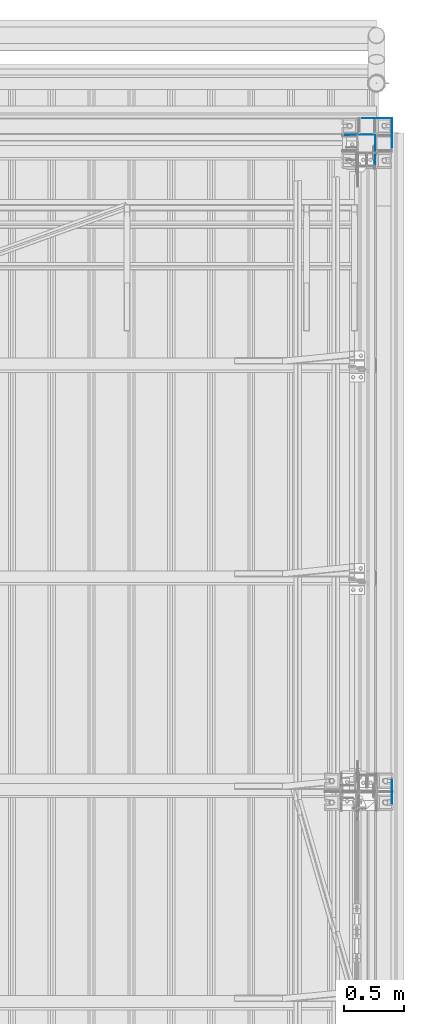
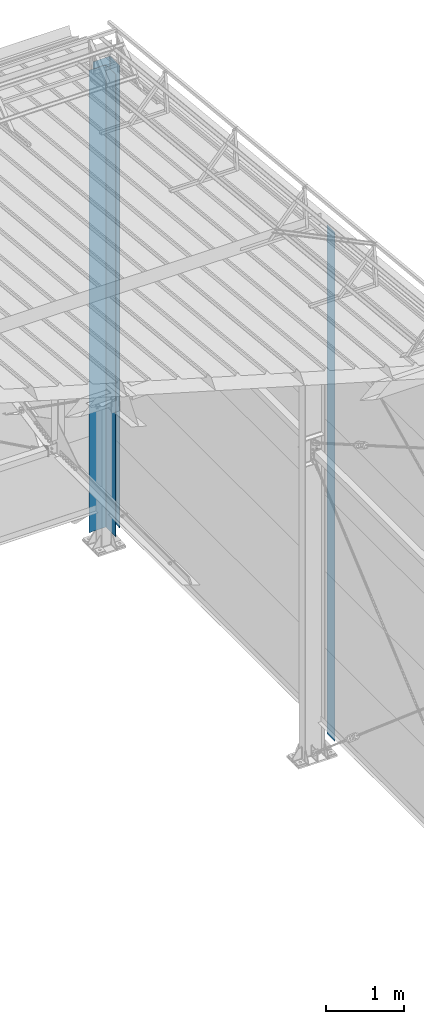
# One storey, part 17 of 709: 3 columns, 3 elements without a shape of their own.
"""IFC4 building model written with IfcOpenShell, lengths in millimetres."""

from ifc_helpers import new_model, si_unit, direction, frame, origin_with_axes, place, context, subcontext, project, spatial, line, indexed_curve, outline, extrude, material, element, aggregate, save


model = new_model("IFC4")

# Units and contexts
model_context = context("Model", 3, precision=0.2, world=origin_with_axes(), true_north=direction((0.0, 1.0)))
body_context = subcontext(model_context, "Body", "Model", "MODEL_VIEW")
ifc_project = project(units=[si_unit("LENGTHUNIT", "METRE", prefix="MILLI"), si_unit("AREAUNIT", "SQUARE_METRE"), si_unit("VOLUMEUNIT", "CUBIC_METRE"), si_unit("MASSUNIT", "GRAM", prefix="KILO"), si_unit("TIMEUNIT", "SECOND"), si_unit("PLANEANGLEUNIT", "RADIAN"), si_unit("SOLIDANGLEUNIT", "STERADIAN"), si_unit("THERMODYNAMICTEMPERATUREUNIT", "DEGREE_CELSIUS"), si_unit("LUMINOUSINTENSITYUNIT", "LUMEN")], contexts=[model_context])

# Site, building, storey
site_placement = place(None, origin_with_axes())
site = spatial("IfcSite", under=ifc_project, at=site_placement, CompositionType="ELEMENT")
building_placement = place(site_placement, origin_with_axes())
building = spatial("IfcBuilding", under=site, at=building_placement, Name="Undefined", CompositionType="ELEMENT")
storey_placement = place(building_placement, origin_with_axes())
storey = spatial("IfcBuildingStorey", under=building, at=storey_placement, Name="Undefined", CompositionType="ELEMENT", Elevation=0.0)

# Assembly, column
assembly_1_placement = place(storey_placement, frame((50130.0, 22130.0, 0.0), z_axis=(0.0, -1.0, 0.0), x_axis=(0.0, 0.0, 1.0)))
assembly_1 = element("IfcElementAssembly", 1, at=assembly_1_placement, inside=storey)
ifc_material = material(Name="Steel_Undefined", Category="STEEL")
column_1_placement = place(assembly_1_placement, origin_with_axes())
column_1 = element("IfcColumn", 2, at=column_1_placement, material=ifc_material, context=body_context, shape_type="SolidModel", body=[
    extrude(outline(indexed_curve([(0.0, 0.0), (250.0, 0.0), (250.0, 3.0), (220.0, 3.0), (220.0, 2.0), (249.0, 2.0), (249.0, 1.0), (1.0, 1.0), (1.0, 249.0), (2.0, 249.0), (2.0, 220.0), (3.0, 220.0), (3.0, 250.0), (0.0, 250.0)], segments=[line(1, 2, 3, 4, 5, 6, 7, 8, 9, 10, 11, 12, 13, 14, 1)])), frame((0.0, 0.0, 0.0), z_axis=(-1.0, 0.0, 0.0), x_axis=(0.0, 0.0, 1.0)), (0.0, 0.0, -1.0), 7196.92297),
])
aggregate(assembly_1, [column_1])

assembly_2_placement = place(storey_placement, frame((49990.0, 21990.0, 0.0), z_axis=(0.0, -1.0, 0.0), x_axis=(0.0, 0.0, 1.0)))
assembly_2 = element("IfcElementAssembly", 3, at=assembly_2_placement, inside=storey)
column_2_placement = place(assembly_2_placement, origin_with_axes())
column_2 = element("IfcColumn", 4, at=column_2_placement, material=ifc_material, context=body_context, shape_type="SolidModel", body=[
    extrude(outline(indexed_curve([(0.0, 0.0), (250.0, 0.0), (250.0, 3.0), (220.0, 3.0), (220.0, 2.0), (249.0, 2.0), (249.0, 1.0), (1.0, 1.0), (1.0, 249.0), (2.0, 249.0), (2.0, 220.0), (3.0, 220.0), (3.0, 250.0), (0.0, 250.0)], segments=[line(1, 2, 3, 4, 5, 6, 7, 8, 9, 10, 11, 12, 13, 14, 1)])), frame((0.0, 0.0, 0.0), z_axis=(-1.0, 0.0, 0.0), x_axis=(0.0, 0.0, 1.0)), (0.0, 0.0, -1.0), 7196.92297),
])
aggregate(assembly_2, [column_2])

assembly_3_placement = place(storey_placement, frame((50130.0, 16500.0, 0.0), z_axis=(1.0, 0.0, 0.0), x_axis=(0.0, 0.0, 1.0)))
assembly_3 = element("IfcElementAssembly", 5, at=assembly_3_placement, inside=storey)
column_3_placement = place(assembly_3_placement, origin_with_axes())
column_3 = element("IfcColumn", 6, at=column_3_placement, material=ifc_material, context=body_context, shape_type="SolidModel", body=[
    extrude(outline(indexed_curve([(-0.375, -100.0), (1.245, -100.0), (1.245, -50.0), (0.495, -50.0), (0.495, -99.25), (0.375, -99.25), (0.375, 99.25), (0.495, 99.25), (0.495, 50.0), (1.245, 50.0), (1.245, 100.0), (-0.375, 100.0)], segments=[line(1, 2, 3, 4, 5, 6, 7, 8, 9, 10, 11, 12, 1)])), frame((0.0, 0.0, 0.0), z_axis=(-1.0, 0.0, 0.0), x_axis=(0.0, 0.0, 1.0)), (0.0, 0.0, -1.0), 7929.67111),
])
aggregate(assembly_3, [column_3])

save(model, "model.ifc")
